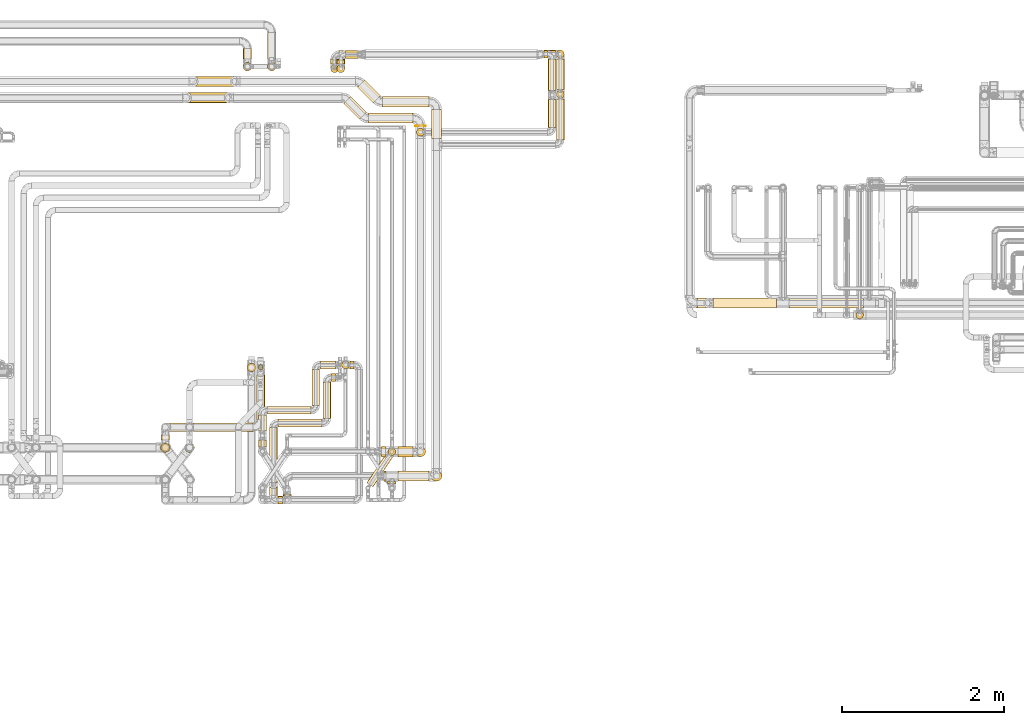
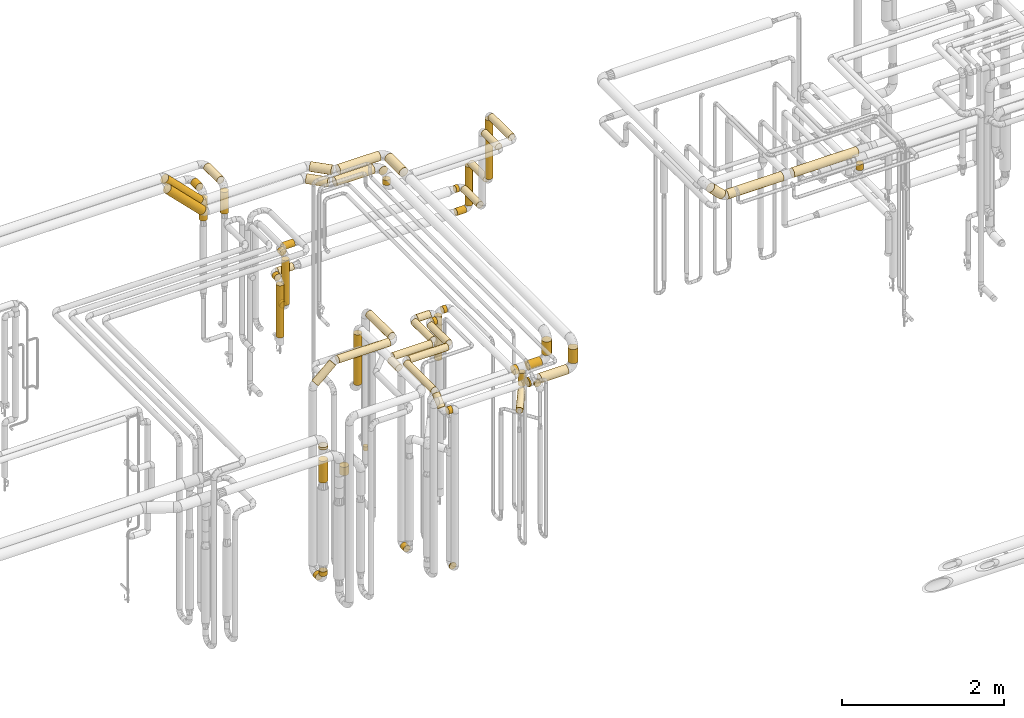
# One storey, part 16 of 827: 66 coverings.
"""IFC2X3 building model written with IfcOpenShell, lengths in millimetres."""

from ifc_helpers import new_model, entity, si_unit, converted_unit, derived_unit, direction, frame, origin, origin_2d_with_axis, place, context, subcontext, project, spatial, circle, extrude, element, save


model = new_model("IFC2X3")

# Units and contexts
model_context = context("Model", 3, precision=0.01, world=origin(), true_north=direction((6.12303176911189e-17, 1.0)))
body_context = subcontext(model_context, "Body", "Model", "MODEL_VIEW")
ifc_project = project(units=[si_unit("LENGTHUNIT", "METRE", prefix="MILLI"), si_unit("AREAUNIT", "SQUARE_METRE"), si_unit("VOLUMEUNIT", "CUBIC_METRE"), converted_unit("PLANEANGLEUNIT", "DEGREE", entity("IfcRatioMeasure", 0.0174532925199433), si_unit("PLANEANGLEUNIT", "RADIAN"), dimensions=[0, 0, 0, 0, 0, 0, 0]), si_unit("MASSUNIT", "GRAM", prefix="KILO"), derived_unit("MASSDENSITYUNIT", [(si_unit("MASSUNIT", "GRAM", prefix="KILO"), 1), (si_unit("LENGTHUNIT", "METRE"), -3)]), derived_unit("MOMENTOFINERTIAUNIT", [(si_unit("LENGTHUNIT", "METRE"), 4)]), si_unit("TIMEUNIT", "SECOND"), si_unit("FREQUENCYUNIT", "HERTZ"), si_unit("THERMODYNAMICTEMPERATUREUNIT", "DEGREE_CELSIUS"), derived_unit("THERMALTRANSMITTANCEUNIT", [(si_unit("MASSUNIT", "GRAM", prefix="KILO"), 1), (si_unit("THERMODYNAMICTEMPERATUREUNIT", "KELVIN"), -1), (si_unit("TIMEUNIT", "SECOND"), -3)]), derived_unit("VOLUMETRICFLOWRATEUNIT", [(si_unit("LENGTHUNIT", "METRE"), 3), (si_unit("TIMEUNIT", "SECOND"), -1)]), derived_unit("MASSFLOWRATEUNIT", [(si_unit("MASSUNIT", "GRAM", prefix="KILO"), 1), (si_unit("TIMEUNIT", "SECOND"), -1)]), derived_unit("ROTATIONALFREQUENCYUNIT", [(si_unit("TIMEUNIT", "SECOND"), -1)]), si_unit("ELECTRICCURRENTUNIT", "AMPERE"), si_unit("ELECTRICVOLTAGEUNIT", "VOLT"), si_unit("POWERUNIT", "WATT"), si_unit("FORCEUNIT", "NEWTON", prefix="KILO"), si_unit("ILLUMINANCEUNIT", "LUX"), si_unit("LUMINOUSFLUXUNIT", "LUMEN"), si_unit("LUMINOUSINTENSITYUNIT", "CANDELA"), derived_unit("USERDEFINED", [(si_unit("MASSUNIT", "GRAM", prefix="KILO"), -1), (si_unit("LENGTHUNIT", "METRE"), -2), (si_unit("TIMEUNIT", "SECOND"), 3), (si_unit("LUMINOUSFLUXUNIT", "LUMEN"), 1)]), derived_unit("LINEARVELOCITYUNIT", [(si_unit("LENGTHUNIT", "METRE"), 1), (si_unit("TIMEUNIT", "SECOND"), -1)]), si_unit("PRESSUREUNIT", "PASCAL"), derived_unit("USERDEFINED", [(si_unit("LENGTHUNIT", "METRE"), -2), (si_unit("MASSUNIT", "GRAM", prefix="KILO"), 1), (si_unit("TIMEUNIT", "SECOND"), -2)]), derived_unit("LINEARFORCEUNIT", [(si_unit("MASSUNIT", "GRAM", prefix="KILO"), 1), (si_unit("LENGTHUNIT", "METRE"), 1), (si_unit("TIMEUNIT", "SECOND"), -2), (si_unit("LENGTHUNIT", "METRE"), -1)]), derived_unit("PLANARFORCEUNIT", [(si_unit("MASSUNIT", "GRAM", prefix="KILO"), 1), (si_unit("LENGTHUNIT", "METRE"), 1), (si_unit("TIMEUNIT", "SECOND"), -2), (si_unit("LENGTHUNIT", "METRE"), -2)])], contexts=[model_context])

# Site, building, storey
site_placement = place(None, origin())
site = spatial("IfcSite", under=ifc_project, at=site_placement, CompositionType="ELEMENT")
building_placement = place(site_placement, origin())
building = spatial("IfcBuilding", under=site, at=building_placement, CompositionType="ELEMENT")
storey_placement = place(building_placement, frame((0.0, 0.0, 28200.0)))
storey = spatial("IfcBuildingStorey", under=building, at=storey_placement, Name="08", CompositionType="ELEMENT", Elevation=28200.0)

# Coverings
covering_1_placement = place(storey_placement, frame((48174.38, 18494.16, 2935.65)))
element("IfcCovering", 1, at=covering_1_placement, inside=storey, Name=":ADSK_", ObjectType=":ADSK_", PredefinedType="INSULATION", context=body_context, shape_type="SweptSolid", body=[
    extrude(circle(Radius=62.75, at=origin_2d_with_axis()), frame((0.0, 64.35, 64.35), z_axis=(1.0, 0.0, 0.0), x_axis=(0.0, -1.0, 0.0)), (0.0, 0.0, 1.0), 575.649711574558),
])
covering_2_placement = place(storey_placement, frame((47865.57, 18540.36, 2935.65)))
element("IfcCovering", 2, at=covering_2_placement, inside=storey, Name=":ADSK_", ObjectType=":ADSK_", PredefinedType="INSULATION", context=body_context, shape_type="SweptSolid", body=[
    extrude(circle(Radius=62.75, at=origin_2d_with_axis()), frame((45.97, 241.63, 64.35), z_axis=(0.707106781186485, -0.70710678118661, 0.0), x_axis=(-0.70710678118661, -0.707106781186485, 0.0)), (0.0, 0.0, 1.0), 276.715492530282),
])
covering_3_placement = place(storey_placement, frame((48780.69, 18106.53, 2935.65)))
element("IfcCovering", 3, at=covering_3_placement, inside=storey, Name=":ADSK_", ObjectType=":ADSK_", PredefinedType="INSULATION", context=body_context, shape_type="SweptSolid", body=[
    extrude(circle(Radius=62.75, at=origin_2d_with_axis()), frame((64.35, 0.0, 64.35), z_axis=(0.0, 1.0, 0.0), x_axis=(1.0, 0.0, 0.0)), (0.0, 0.0, 1.0), 356.978263748389),
])
covering_4_placement = place(storey_placement, frame((45805.68, 18744.58, 2981.86)))
element("IfcCovering", 4, at=covering_4_placement, inside=storey, Name=":ADSK_", ObjectType=":ADSK_", PredefinedType="INSULATION", context=body_context, shape_type="SweptSolid", body=[
    extrude(circle(Radius=62.75, at=origin_2d_with_axis()), frame((45.97, 64.35, 540.32), z_axis=(0.70710619769924, 0.00128465974007588, -0.70710619769924), x_axis=(0.000908391613723806, -0.999999174824336, -0.000908391613726204)), (0.0, 0.0, 1.0), 699.117459348992),
])
covering_5_placement = place(storey_placement, frame((48780.69, 13869.16, 2692.43)))
element("IfcCovering", 5, at=covering_5_placement, inside=storey, Name=":ADSK_", ObjectType=":ADSK_", PredefinedType="INSULATION", context=body_context, shape_type="SweptSolid", body=[
    extrude(circle(Radius=62.75, at=origin_2d_with_axis()), frame((64.35, 64.35, 0.0), z_axis=(0.0, 0.0, 1.0), x_axis=(0.0, 1.0, 0.0)), (0.0, 0.0, 1.0), 212.567197891267),
])
covering_6_placement = place(storey_placement, frame((48195.03, 13869.16, 2533.15)))
element("IfcCovering", 6, at=covering_6_placement, inside=storey, Name=":ADSK_", ObjectType=":ADSK_", PredefinedType="INSULATION", context=body_context, shape_type="SweptSolid", body=[
    extrude(circle(Radius=62.75, at=origin_2d_with_axis()), frame((0.0, 64.35, 64.35), z_axis=(1.0, 0.0, 0.0), x_axis=(0.0, -1.0, 0.0)), (0.0, 0.0, 1.0), 20.9896740925879),
])
covering_7_placement = place(storey_placement, frame((48241.43, 13843.1, 2546.9)))
element("IfcCovering", 7, at=covering_7_placement, inside=storey, Name=":ADSK_", ObjectType=":ADSK_", PredefinedType="INSULATION", context=body_context, shape_type="SweptSolid", body=[
    extrude(circle(Radius=49.0, at=origin_2d_with_axis()), frame((50.6, 0.0, 50.6), z_axis=(0.0, 1.0, 0.0), x_axis=(-1.0, 0.0, 0.0)), (0.0, 0.0, 1.0), 23.4071590179462),
])
covering_8_placement = place(storey_placement, frame((48368.02, 13869.16, 2533.15)))
element("IfcCovering", 8, at=covering_8_placement, inside=storey, Name=":ADSK_", ObjectType=":ADSK_", PredefinedType="INSULATION", context=body_context, shape_type="SweptSolid", body=[
    extrude(circle(Radius=62.75, at=origin_2d_with_axis()), frame((0.0, 64.35, 64.35), z_axis=(1.0, 0.0, 0.0), x_axis=(0.0, -1.0, 0.0)), (0.0, 0.0, 1.0), 382.010325907433),
])
covering_9_placement = place(storey_placement, frame((51989.91, 16008.03, 2681.53)))
element("IfcCovering", 9, at=covering_9_placement, inside=storey, Name=":ADSK_", ObjectType=":ADSK_", PredefinedType="INSULATION", context=body_context, shape_type="SweptSolid", body=[
    extrude(circle(Radius=62.75, at=origin_2d_with_axis()), frame((202.15, 64.35, 46.1), z_axis=(-0.709187265322835, 0.0, 0.705020157657863), x_axis=(0.0, 1.0, 0.0)), (0.0, 0.0, 1.0), 220.413379022299),
])
covering_10_placement = place(storey_placement, frame((52259.0, 16008.03, 2635.69)))
element("IfcCovering", 10, at=covering_10_placement, inside=storey, Name=":ADSK_", ObjectType=":ADSK_", PredefinedType="INSULATION", context=body_context, shape_type="SweptSolid", body=[
    extrude(circle(Radius=62.75, at=origin_2d_with_axis()), frame((0.0, 64.35, 64.35), z_axis=(1.0, 0.0, 0.0), x_axis=(0.0, 1.0, 0.0)), (0.0, 0.0, 1.0), 786.054556925048),
])
covering_11_placement = place(storey_placement, frame((53197.06, 16008.03, 2635.69)))
element("IfcCovering", 11, at=covering_11_placement, inside=storey, Name=":ADSK_", ObjectType=":ADSK_", PredefinedType="INSULATION", context=body_context, shape_type="SweptSolid", body=[
    extrude(circle(Radius=62.75, at=origin_2d_with_axis()), frame((0.0, 64.35, 64.35), z_axis=(1.0, 0.0, 0.0), x_axis=(0.0, 1.0, 0.0)), (0.0, 0.0, 1.0), 916.731510000015),
])
covering_12_placement = place(storey_placement, frame((48004.19, 18291.33, 2935.65)))
element("IfcCovering", 12, at=covering_12_placement, inside=storey, Name=":ADSK_", ObjectType=":ADSK_", PredefinedType="INSULATION", context=body_context, shape_type="SweptSolid", body=[
    extrude(circle(Radius=62.75, at=origin_2d_with_axis()), frame((0.0, 64.35, 64.35), z_axis=(1.0, 0.0, 0.0), x_axis=(0.0, -1.0, 0.0)), (0.0, 0.0, 1.0), 545.649711574547),
])
covering_13_placement = place(storey_placement, frame((47695.68, 18337.54, 2935.65)))
element("IfcCovering", 13, at=covering_13_placement, inside=storey, Name=":ADSK_", ObjectType=":ADSK_", PredefinedType="INSULATION", context=body_context, shape_type="SweptSolid", body=[
    extrude(circle(Radius=62.75, at=origin_2d_with_axis()), frame((45.97, 241.34, 64.35), z_axis=(0.707106781186555, -0.70710678118654, 0.0), x_axis=(-0.70710678118654, -0.707106781186555, 0.0)), (0.0, 0.0, 1.0), 276.299423149123),
])
covering_14_placement = place(storey_placement, frame((48580.5, 18256.53, 2935.65)))
element("IfcCovering", 14, at=covering_14_placement, inside=storey, Name=":ADSK_", ObjectType=":ADSK_", PredefinedType="INSULATION", context=body_context, shape_type="SweptSolid", body=[
    extrude(circle(Radius=62.75, at=origin_2d_with_axis()), frame((64.35, 0.0, 64.35), z_axis=(0.0, 1.0, 0.0), x_axis=(1.0, 0.0, 0.0)), (0.0, 0.0, 1.0), 4.1498271651662),
])
covering_15_placement = place(storey_placement, frame((45725.68, 18542.35, 2981.86)))
element("IfcCovering", 15, at=covering_15_placement, inside=storey, Name=":ADSK_", ObjectType=":ADSK_", PredefinedType="INSULATION", context=body_context, shape_type="SweptSolid", body=[
    extrude(circle(Radius=62.75, at=origin_2d_with_axis()), frame((45.97, 64.35, 540.32), z_axis=(0.707106781186548, 0.0, -0.707106781186548), x_axis=(0.0, -1.0, 0.0)), (0.0, 0.0, 1.0), 699.116571318315),
])
covering_16_placement = place(storey_placement, frame((48580.5, 14171.33, 2700.0)))
element("IfcCovering", 16, at=covering_16_placement, inside=storey, Name=":ADSK_", ObjectType=":ADSK_", PredefinedType="INSULATION", context=body_context, shape_type="SweptSolid", body=[
    extrude(circle(Radius=62.75, at=origin_2d_with_axis()), frame((64.35, 64.35, 0.0), z_axis=(0.0, 0.0, 1.0), x_axis=(-1.0, 0.0, 0.0)), (0.0, 0.0, 1.0), 205.000000000018),
])
covering_17_placement = place(storey_placement, frame((48164.84, 14171.33, 2540.65)))
element("IfcCovering", 17, at=covering_17_placement, inside=storey, Name=":ADSK_", ObjectType=":ADSK_", PredefinedType="INSULATION", context=body_context, shape_type="SweptSolid", body=[
    extrude(circle(Radius=62.75, at=origin_2d_with_axis()), frame((0.0, 64.35, 64.35), z_axis=(1.0, 0.0, 0.0), x_axis=(0.0, -1.0, 0.0)), (0.0, 0.0, 1.0), 51.1810195864036),
])
covering_18_placement = place(storey_placement, frame((48244.28, 14187.93, 2117.5)))
element("IfcCovering", 18, at=covering_18_placement, inside=storey, Name=":ADSK_", ObjectType=":ADSK_", PredefinedType="INSULATION", context=body_context, shape_type="SweptSolid", body=[
    extrude(circle(Radius=46.15, at=origin_2d_with_axis()), frame((47.75, 47.75, 0.0), z_axis=(0.0, 0.0, 1.0), x_axis=(0.0, 1.0, 0.0)), (0.0, 0.0, 1.0), 134.500000000013),
])
covering_19_placement = place(storey_placement, frame((48368.02, 14171.33, 2540.65)))
element("IfcCovering", 19, at=covering_19_placement, inside=storey, Name=":ADSK_", ObjectType=":ADSK_", PredefinedType="INSULATION", context=body_context, shape_type="SweptSolid", body=[
    extrude(circle(Radius=62.75, at=origin_2d_with_axis()), frame((0.0, 64.35, 64.35), z_axis=(1.0, 0.0, 0.0), x_axis=(0.0, -1.0, 0.0)), (0.0, 0.0, 1.0), 181.818980413621),
])
covering_20_placement = place(storey_placement, frame((47980.98, 13799.35, 2252.25)))
element("IfcCovering", 20, at=covering_20_placement, inside=storey, Name=":ADSK_", ObjectType=":ADSK_", PredefinedType="INSULATION", context=body_context, shape_type="SweptSolid", body=[
    extrude(circle(Radius=46.15, at=origin_2d_with_axis()), frame((40.1, 27.03, 47.75), z_axis=(0.551214458685239, 0.834363602116211, 0.0), x_axis=(-0.834363602116211, 0.551214458685239, 0.0)), (0.0, 0.0, 1.0), 442.846744306639),
])
covering_21_placement = place(storey_placement, frame((48244.28, 14187.93, 2348.0)))
element("IfcCovering", 21, at=covering_21_placement, inside=storey, Name=":ADSK_", ObjectType=":ADSK_", PredefinedType="INSULATION", context=body_context, shape_type="SweptSolid", body=[
    extrude(circle(Radius=46.15, at=origin_2d_with_axis()), frame((47.75, 47.75, 0.0), z_axis=(0.0, 0.0, 1.0), x_axis=(0.0, 1.0, 0.0)), (0.0, 0.0, 1.0), 192.999999999991),
])
covering_22_placement = place(storey_placement, frame((46453.47, 19086.22, 2945.65)))
element("IfcCovering", 22, at=covering_22_placement, inside=storey, Name=":ADSK_", ObjectType=":ADSK_", PredefinedType="INSULATION", context=body_context, shape_type="SweptSolid", body=[
    extrude(circle(Radius=52.75, at=origin_2d_with_axis()), frame((54.35, 0.0, 54.35), z_axis=(0.0, 1.0, 0.0), x_axis=(1.0, 0.0, 0.0)), (0.0, 0.0, 1.0), 126.011600000002),
])
covering_23_placement = place(storey_placement, frame((46453.47, 18936.88, 2580.0)))
element("IfcCovering", 23, at=covering_23_placement, inside=storey, Name=":ADSK_", ObjectType=":ADSK_", PredefinedType="INSULATION", context=body_context, shape_type="SweptSolid", body=[
    extrude(circle(Radius=52.75, at=origin_2d_with_axis()), frame((54.35, 54.35, 0.0), z_axis=(0.0, 0.0, 1.0), x_axis=(-1.0, 0.0, 0.0)), (0.0, 0.0, 1.0), 325.000000000008),
])
covering_24_placement = place(storey_placement, frame((54022.04, 15874.63, 2548.0)))
element("IfcCovering", 24, at=covering_24_placement, inside=storey, Name=":ADSK_", ObjectType=":ADSK_", PredefinedType="INSULATION", context=body_context, shape_type="SweptSolid", body=[
    extrude(circle(Radius=46.15, at=origin_2d_with_axis()), frame((47.75, 47.75, 0.0), z_axis=(0.0, 0.0, 1.0), x_axis=(-1.0, 0.0, 0.0)), (0.0, 0.0, 1.0), 87.999999999941),
])
covering_25_placement = place(storey_placement, frame((47301.4, 14804.03, 2949.4)))
element("IfcCovering", 25, at=covering_25_placement, inside=storey, Name=":ADSK_", ObjectType=":ADSK_", PredefinedType="INSULATION", context=body_context, shape_type="SweptSolid", body=[
    extrude(circle(Radius=49.0, at=origin_2d_with_axis()), frame((50.6, 0.0, 50.6), z_axis=(0.0, 1.0, 0.0), x_axis=(1.0, 0.0, 0.0)), (0.0, 0.0, 1.0), 446.000000000016),
])
covering_26_placement = place(storey_placement, frame((46642.19, 14296.53, 349.4)))
element("IfcCovering", 26, at=covering_26_placement, inside=storey, Name=":ADSK_", ObjectType=":ADSK_", PredefinedType="INSULATION", context=body_context, shape_type="SweptSolid", body=[
    extrude(circle(Radius=49.0, at=origin_2d_with_axis()), frame((50.6, 0.0, 50.6), z_axis=(0.0, 1.0, 0.0), x_axis=(1.0, 0.0, 0.0)), (0.0, 0.0, 1.0), 81.0000000000119),
])
covering_27_placement = place(storey_placement, frame((47409.0, 15256.43, 2949.4)))
element("IfcCovering", 27, at=covering_27_placement, inside=storey, Name=":ADSK_", ObjectType=":ADSK_", PredefinedType="INSULATION", context=body_context, shape_type="SweptSolid", body=[
    extrude(circle(Radius=49.0, at=origin_2d_with_axis()), frame((0.0, 50.6, 50.6), z_axis=(1.0, 0.0, 0.0), x_axis=(0.0, 1.0, 0.0)), (0.0, 0.0, 1.0), 186.00000000001),
])
covering_28_placement = place(storey_placement, frame((46749.79, 14696.43, 2949.4)))
element("IfcCovering", 28, at=covering_28_placement, inside=storey, Name=":ADSK_", ObjectType=":ADSK_", PredefinedType="INSULATION", context=body_context, shape_type="SweptSolid", body=[
    extrude(circle(Radius=49.0, at=origin_2d_with_axis()), frame((0.0, 50.6, 50.6), z_axis=(1.0, 0.0, 0.0), x_axis=(0.0, -1.0, 0.0)), (0.0, 0.0, 1.0), 545.208916433662),
])
covering_29_placement = place(storey_placement, frame((46642.19, 14491.53, 2949.4)))
element("IfcCovering", 29, at=covering_29_placement, inside=storey, Name=":ADSK_", ObjectType=":ADSK_", PredefinedType="INSULATION", context=body_context, shape_type="SweptSolid", body=[
    extrude(circle(Radius=49.0, at=origin_2d_with_axis()), frame((50.6, 0.0, 50.6), z_axis=(0.0, 1.0, 0.0), x_axis=(-1.0, 0.0, 0.0)), (0.0, 0.0, 1.0), 198.500000000011),
])
covering_30_placement = place(storey_placement, frame((47777.26, 15256.43, 2949.4)))
element("IfcCovering", 30, at=covering_30_placement, inside=storey, Name=":ADSK_", ObjectType=":ADSK_", PredefinedType="INSULATION", context=body_context, shape_type="SweptSolid", body=[
    extrude(circle(Radius=49.0, at=origin_2d_with_axis()), frame((0.0, 50.6, 50.6), z_axis=(1.0, 0.0, 0.0), x_axis=(0.0, -1.0, 0.0)), (0.0, 0.0, 1.0), 49.749999999993),
])
covering_31_placement = place(storey_placement, frame((47669.42, 15256.43, 2287.62)))
element("IfcCovering", 31, at=covering_31_placement, inside=storey, Name=":ADSK_", ObjectType=":ADSK_", PredefinedType="INSULATION", context=body_context, shape_type="SweptSolid", body=[
    extrude(circle(Radius=49.0, at=origin_2d_with_axis()), frame((50.6, 50.6, 0.0), z_axis=(0.0, 0.0, 1.0), x_axis=(-1.0, 0.0, 0.0)), (0.0, 0.0, 1.0), 655.375000000061),
])
covering_32_placement = place(storey_placement, frame((47437.4, 14645.75, 2949.4)))
element("IfcCovering", 32, at=covering_32_placement, inside=storey, Name=":ADSK_", ObjectType=":ADSK_", PredefinedType="INSULATION", context=body_context, shape_type="SweptSolid", body=[
    extrude(circle(Radius=49.0, at=origin_2d_with_axis()), frame((50.6, 0.0, 50.6), z_axis=(0.0, 1.0, 0.0), x_axis=(1.0, 0.0, 0.0)), (0.0, 0.0, 1.0), 448.489185095073),
])
covering_33_placement = place(storey_placement, frame((46947.93, 13694.22, 349.4)))
element("IfcCovering", 33, at=covering_33_placement, inside=storey, Name=":ADSK_", ObjectType=":ADSK_", PredefinedType="INSULATION", context=body_context, shape_type="SweptSolid", body=[
    extrude(circle(Radius=49.0, at=origin_2d_with_axis()), frame((50.6, 0.0, 50.6), z_axis=(0.0, 1.0, 0.0), x_axis=(-1.0, 0.0, 0.0)), (0.0, 0.0, 1.0), 12.5440336639325),
])
covering_34_placement = place(storey_placement, frame((47545.0, 15100.64, 2949.4)))
element("IfcCovering", 34, at=covering_34_placement, inside=storey, Name=":ADSK_", ObjectType=":ADSK_", PredefinedType="INSULATION", context=body_context, shape_type="SweptSolid", body=[
    extrude(circle(Radius=49.0, at=origin_2d_with_axis()), frame((0.0, 50.6, 50.6), z_axis=(1.0, 0.0, 0.0), x_axis=(0.0, 1.0, 0.0)), (0.0, 0.0, 1.0), 49.749999999993),
])
covering_35_placement = place(storey_placement, frame((46885.0, 13586.24, 2759.19)))
element("IfcCovering", 35, at=covering_35_placement, inside=storey, Name=":ADSK_", ObjectType=":ADSK_", PredefinedType="INSULATION", context=body_context, shape_type="SweptSolid", body=[
    extrude(circle(Radius=49.0, at=origin_2d_with_axis()), frame((0.0, 50.6, 50.6), z_axis=(1.0, -2.35333717118907e-08, 0.0), x_axis=(-2.35333717118907e-08, -1.0, 0.0)), (0.0, 0.0, 1.0), 56.5308175749362),
])
covering_36_placement = place(storey_placement, frame((46885.0, 14538.15, 2949.4)))
element("IfcCovering", 36, at=covering_36_placement, inside=storey, Name=":ADSK_", ObjectType=":ADSK_", PredefinedType="INSULATION", context=body_context, shape_type="SweptSolid", body=[
    extrude(circle(Radius=49.0, at=origin_2d_with_axis()), frame((0.0, 50.6, 50.6), z_axis=(1.0, 0.0, 0.0), x_axis=(0.0, -1.0, 0.0)), (0.0, 0.0, 1.0), 546.000000000006),
])
covering_37_placement = place(storey_placement, frame((46777.4, 13856.65, 2949.4)))
element("IfcCovering", 37, at=covering_37_placement, inside=storey, Name=":ADSK_", ObjectType=":ADSK_", PredefinedType="INSULATION", context=body_context, shape_type="SweptSolid", body=[
    extrude(circle(Radius=49.0, at=origin_2d_with_axis()), frame((50.6, 0.0, 50.6), z_axis=(0.0, 1.0, 0.0), x_axis=(1.0, 0.0, 0.0)), (0.0, 0.0, 1.0), 675.09993070178),
])
covering_38_placement = place(storey_placement, frame((46777.4, 13642.17, 2812.58)))
element("IfcCovering", 38, at=covering_38_placement, inside=storey, Name=":ADSK_", ObjectType=":ADSK_", PredefinedType="INSULATION", context=body_context, shape_type="SweptSolid", body=[
    extrude(circle(Radius=49.0, at=origin_2d_with_axis()), frame((50.6, 35.65, 36.82), z_axis=(0.0, 0.718969901615608, 0.695041207822128), x_axis=(-1.0, 0.0, 0.0)), (0.0, 0.0, 1.0), 193.624123419369),
])
covering_39_placement = place(storey_placement, frame((50221.44, 18237.53, 2749.4)))
element("IfcCovering", 39, at=covering_39_placement, inside=storey, Name=":ADSK_", ObjectType=":ADSK_", PredefinedType="INSULATION", context=body_context, shape_type="SweptSolid", body=[
    extrude(circle(Radius=49.0, at=origin_2d_with_axis()), frame((50.6, 0.0, 50.6), z_axis=(0.0, 1.0, 0.0), x_axis=(-1.0, 0.0, 0.0)), (0.0, 0.0, 1.0), 345.999999999954),
])
covering_40_placement = place(storey_placement, frame((48594.25, 18129.93, 2857.0)))
element("IfcCovering", 40, at=covering_40_placement, inside=storey, Name=":ADSK_", ObjectType=":ADSK_", PredefinedType="INSULATION", context=body_context, shape_type="SweptSolid", body=[
    extrude(circle(Radius=49.0, at=origin_2d_with_axis()), frame((50.6, 50.6, 0.0)), (0.0, 0.0, 1.0), 75.9999999999611),
])
covering_41_placement = place(storey_placement, frame((50221.44, 18697.53, 1599.4)))
element("IfcCovering", 41, at=covering_41_placement, inside=storey, Name=":ADSK_", ObjectType=":ADSK_", PredefinedType="INSULATION", context=body_context, shape_type="SweptSolid", body=[
    extrude(circle(Radius=49.0, at=origin_2d_with_axis()), frame((50.6, 0.0, 50.6), z_axis=(0.0, 1.0, 0.0), x_axis=(-1.0, 0.0, 0.0)), (0.0, 0.0, 1.0), 390.99999997821),
])
covering_42_placement = place(storey_placement, frame((50172.3, 19094.93, 1599.4)))
element("IfcCovering", 42, at=covering_42_placement, inside=storey, Name=":ADSK_", ObjectType=":ADSK_", PredefinedType="INSULATION", context=body_context, shape_type="SweptSolid", body=[
    extrude(circle(Radius=49.0, at=origin_2d_with_axis()), frame((0.0, 50.6, 50.6), z_axis=(1.0, 0.0, 0.0), x_axis=(0.0, -1.0, 0.0)), (0.0, 0.0, 1.0), 42.7379771478646),
])
covering_43_placement = place(storey_placement, frame((47718.17, 19090.63, 1599.4)))
element("IfcCovering", 43, at=covering_43_placement, inside=storey, Name=":ADSK_", ObjectType=":ADSK_", PredefinedType="INSULATION", context=body_context, shape_type="SweptSolid", body=[
    extrude(circle(Radius=49.0, at=origin_2d_with_axis()), frame((0.0, 50.6, 50.6), z_axis=(1.0, 0.0, 0.0), x_axis=(0.0, -1.0, 0.0)), (0.0, 0.0, 1.0), 156.125000000036),
])
covering_44_placement = place(storey_placement, frame((47610.58, 19023.22, 1599.4)))
element("IfcCovering", 44, at=covering_44_placement, inside=storey, Name=":ADSK_", ObjectType=":ADSK_", PredefinedType="INSULATION", context=body_context, shape_type="SweptSolid", body=[
    extrude(circle(Radius=49.0, at=origin_2d_with_axis()), frame((50.6, 0.0, 50.6), z_axis=(0.0, 1.0, 0.0), x_axis=(1.0, 0.0, 0.0)), (0.0, 0.0, 1.0), 61.0000000000208),
])
covering_45_placement = place(storey_placement, frame((47610.58, 18915.63, 918.88)))
element("IfcCovering", 45, at=covering_45_placement, inside=storey, Name=":ADSK_", ObjectType=":ADSK_", PredefinedType="INSULATION", context=body_context, shape_type="SweptSolid", body=[
    extrude(circle(Radius=49.0, at=origin_2d_with_axis()), frame((50.6, 50.6, 0.0), z_axis=(0.0, 0.0, 1.0), x_axis=(-1.0, 0.0, 0.0)), (0.0, 0.0, 1.0), 674.12499999997),
])
covering_46_placement = place(storey_placement, frame((47610.58, 19023.22, 811.28)))
element("IfcCovering", 46, at=covering_46_placement, inside=storey, Name=":ADSK_", ObjectType=":ADSK_", PredefinedType="INSULATION", context=body_context, shape_type="SweptSolid", body=[
    extrude(circle(Radius=49.0, at=origin_2d_with_axis()), frame((50.6, 0.0, 50.6), z_axis=(0.0, 1.0, 0.0), x_axis=(-1.0, 0.0, 0.0)), (0.0, 0.0, 1.0), 48.0000000000086),
])
covering_47_placement = place(storey_placement, frame((50321.44, 18087.53, 2949.4)))
element("IfcCovering", 47, at=covering_47_placement, inside=storey, Name=":ADSK_", ObjectType=":ADSK_", PredefinedType="INSULATION", context=body_context, shape_type="SweptSolid", body=[
    extrude(circle(Radius=49.0, at=origin_2d_with_axis()), frame((50.6, 0.0, 50.6), z_axis=(0.0, 1.0, 0.0), x_axis=(-1.0, 0.0, 0.0)), (0.0, 0.0, 1.0), 506.000000000015),
])
covering_48_placement = place(storey_placement, frame((50321.44, 18599.93, 2057.0)))
element("IfcCovering", 48, at=covering_48_placement, inside=storey, Name=":ADSK_", ObjectType=":ADSK_", PredefinedType="INSULATION", context=body_context, shape_type="SweptSolid", body=[
    extrude(circle(Radius=49.0, at=origin_2d_with_axis()), frame((50.6, 50.6, 0.0), z_axis=(0.0, 0.0, 1.0), x_axis=(-1.0, 0.0, 0.0)), (0.0, 0.0, 1.0), 886.000000000011),
])
covering_49_placement = place(storey_placement, frame((50321.44, 18707.53, 1949.4)))
element("IfcCovering", 49, at=covering_49_placement, inside=storey, Name=":ADSK_", ObjectType=":ADSK_", PredefinedType="INSULATION", context=body_context, shape_type="SweptSolid", body=[
    extrude(circle(Radius=49.0, at=origin_2d_with_axis()), frame((50.6, 0.0, 50.6), z_axis=(0.0, 1.0, 0.0), x_axis=(-1.0, 0.0, 0.0)), (0.0, 0.0, 1.0), 381.000000000007),
])
covering_50_placement = place(storey_placement, frame((50321.44, 19094.93, 1357.0)))
element("IfcCovering", 50, at=covering_50_placement, inside=storey, Name=":ADSK_", ObjectType=":ADSK_", PredefinedType="INSULATION", context=body_context, shape_type="SweptSolid", body=[
    extrude(circle(Radius=49.0, at=origin_2d_with_axis()), frame((50.6, 50.6, 0.0), z_axis=(0.0, 0.0, 1.0), x_axis=(-1.0, 0.0, 0.0)), (0.0, 0.0, 1.0), 586.00000000001),
])
covering_51_placement = place(storey_placement, frame((50185.03, 19094.93, 1249.4)))
element("IfcCovering", 51, at=covering_51_placement, inside=storey, Name=":ADSK_", ObjectType=":ADSK_", PredefinedType="INSULATION", context=body_context, shape_type="SweptSolid", body=[
    extrude(circle(Radius=49.0, at=origin_2d_with_axis()), frame((0.0, 50.6, 50.6), z_axis=(1.0, 0.0, 0.0), x_axis=(0.0, -1.0, 0.0)), (0.0, 0.0, 1.0), 130.000000000005),
])
covering_52_placement = place(storey_placement, frame((47641.3, 19090.63, 1249.4)))
element("IfcCovering", 52, at=covering_52_placement, inside=storey, Name=":ADSK_", ObjectType=":ADSK_", PredefinedType="INSULATION", context=body_context, shape_type="SweptSolid", body=[
    extrude(circle(Radius=49.0, at=origin_2d_with_axis()), frame((0.0, 50.6, 50.6), z_axis=(1.0, 0.0, 0.0), x_axis=(0.0, -1.0, 0.0)), (0.0, 0.0, 1.0), 220.000000000002),
])
covering_53_placement = place(storey_placement, frame((47533.7, 19023.22, 1249.4)))
element("IfcCovering", 53, at=covering_53_placement, inside=storey, Name=":ADSK_", ObjectType=":ADSK_", PredefinedType="INSULATION", context=body_context, shape_type="SweptSolid", body=[
    extrude(circle(Radius=49.0, at=origin_2d_with_axis()), frame((50.6, 0.0, 50.6), z_axis=(0.0, 1.0, 0.0), x_axis=(1.0, 0.0, 0.0)), (0.0, 0.0, 1.0), 61.0000000000143),
])
covering_54_placement = place(storey_placement, frame((47533.7, 18915.63, 457.0)))
element("IfcCovering", 54, at=covering_54_placement, inside=storey, Name=":ADSK_", ObjectType=":ADSK_", PredefinedType="INSULATION", context=body_context, shape_type="SweptSolid", body=[
    extrude(circle(Radius=49.0, at=origin_2d_with_axis()), frame((50.6, 50.6, 0.0)), (0.0, 0.0, 1.0), 785.999999709128),
])
covering_55_placement = place(storey_placement, frame((45439.88, 14381.62, 295.65)))
element("IfcCovering", 55, at=covering_55_placement, inside=storey, Name=":ADSK_", ObjectType=":ADSK_", PredefinedType="INSULATION", context=body_context, shape_type="SweptSolid", body=[
    extrude(circle(Radius=52.75, at=origin_2d_with_axis()), frame((54.35, 0.0, 54.35), z_axis=(0.0, 1.0, 0.0), x_axis=(1.0, 0.0, 0.0)), (0.0, 0.0, 1.0), 61.4604775254828),
])
covering_56_placement = place(storey_placement, frame((45439.88, 14232.27, 445.0)))
element("IfcCovering", 56, at=covering_56_placement, inside=storey, Name=":ADSK_", ObjectType=":ADSK_", PredefinedType="INSULATION", context=body_context, shape_type="SweptSolid", body=[
    extrude(circle(Radius=52.75, at=origin_2d_with_axis()), frame((54.35, 54.35, 0.0)), (0.0, 0.0, 1.0), 65.0000000000242),
])
covering_57_placement = place(storey_placement, frame((45841.83, 14483.73, 3345.65)))
element("IfcCovering", 57, at=covering_57_placement, inside=storey, Name=":ADSK_", ObjectType=":ADSK_", PredefinedType="INSULATION", context=body_context, shape_type="SweptSolid", body=[
    extrude(circle(Radius=52.75, at=origin_2d_with_axis()), frame((0.0, 54.35, 54.35), z_axis=(1.0, 0.0, 0.0), x_axis=(0.0, -1.0, 0.0)), (0.0, 0.0, 1.0), 733.72992241483),
])
covering_58_placement = place(storey_placement, frame((46616.22, 14633.08, 3345.65)))
element("IfcCovering", 58, at=covering_58_placement, inside=storey, Name=":ADSK_", ObjectType=":ADSK_", PredefinedType="INSULATION", context=body_context, shape_type="SweptSolid", body=[
    extrude(circle(Radius=52.75, at=origin_2d_with_axis()), frame((54.35, 0.0, 54.35), z_axis=(0.0, 1.0, 0.0), x_axis=(-1.0, 0.0, 0.0)), (0.0, 0.0, 1.0), 550.000000000011),
])
covering_59_placement = place(storey_placement, frame((45489.92, 14483.73, 3112.41)))
element("IfcCovering", 59, at=covering_59_placement, inside=storey, Name=":ADSK_", ObjectType=":ADSK_", PredefinedType="INSULATION", context=body_context, shape_type="SweptSolid", body=[
    extrude(circle(Radius=52.75, at=origin_2d_with_axis()), frame((36.48, 54.35, 41.17), z_axis=(0.750137300458903, 0.0, 0.661282111099514), x_axis=(0.0, 1.0, 0.0)), (0.0, 0.0, 1.0), 336.753261279577),
])
covering_60_placement = place(storey_placement, frame((45433.82, 14226.22, 1854.0)))
element("IfcCovering", 60, at=covering_60_placement, inside=storey, Name=":ADSK_", ObjectType=":ADSK_", PredefinedType="INSULATION", context=body_context, shape_type="SweptSolid", body=[
    extrude(circle(Radius=59.25, at=origin_2d_with_axis()), frame((60.4, 60.4, 0.0), z_axis=(0.0, 0.0, 1.0), x_axis=(-0.798635510047303, -0.601815023152035, 0.0)), (0.0, 0.0, 1.0), 325.000000000008),
])
covering_61_placement = place(storey_placement, frame((46636.47, 15243.98, 1305.25)))
element("IfcCovering", 61, at=covering_61_placement, inside=storey, Name=":ADSK_", ObjectType=":ADSK_", PredefinedType="INSULATION", context=body_context, shape_type="SweptSolid", body=[
    extrude(circle(Radius=32.5, at=origin_2d_with_axis()), frame((34.1, 34.1, 0.0), z_axis=(0.0, 0.0, 1.0), x_axis=(0.0, -1.0, 0.0)), (0.0, 0.0, 1.0), 61.0000000000035),
])
covering_62_placement = place(storey_placement, frame((46502.43, 15221.02, 2345.05)))
element("IfcCovering", 62, at=covering_62_placement, inside=storey, Name=":ADSK_", ObjectType=":ADSK_", PredefinedType="INSULATION", context=body_context, shape_type="SweptSolid", body=[
    extrude(circle(Radius=52.75, at=origin_2d_with_axis()), frame((54.35, 54.35, 0.0)), (0.0, 0.0, 1.0), 760.000000000018),
])
covering_63_placement = place(storey_placement, frame((45732.67, 14226.22, 1860.0)))
element("IfcCovering", 63, at=covering_63_placement, inside=storey, Name=":ADSK_", ObjectType=":ADSK_", PredefinedType="INSULATION", context=body_context, shape_type="SweptSolid", body=[
    extrude(circle(Radius=59.25, at=origin_2d_with_axis()), frame((60.4, 60.4, 0.0), z_axis=(0.0, 0.0, 1.0), x_axis=(0.798635510047289, -0.601815023152053, 0.0)), (0.0, 0.0, 1.0), 126.000000000019),
])
covering_64_placement = place(storey_placement, frame((46753.22, 19086.22, 2945.4)))
element("IfcCovering", 64, at=covering_64_placement, inside=storey, Name=":ADSK_", ObjectType=":ADSK_", PredefinedType="INSULATION", context=body_context, shape_type="SweptSolid", body=[
    extrude(circle(Radius=53.0, at=origin_2d_with_axis()), frame((54.6, 0.0, 54.6), z_axis=(0.0, 1.0, 0.0), x_axis=(1.0, 0.0, 0.0)), (0.0, 0.0, 1.0), 326.0116),
])
covering_65_placement = place(storey_placement, frame((46753.22, 18936.63, 2580.0)))
element("IfcCovering", 65, at=covering_65_placement, inside=storey, Name=":ADSK_", ObjectType=":ADSK_", PredefinedType="INSULATION", context=body_context, shape_type="SweptSolid", body=[
    extrude(circle(Radius=53.0, at=origin_2d_with_axis()), frame((54.6, 54.6, 0.0)), (0.0, 0.0, 1.0), 325.000000000017),
])
covering_66_placement = place(storey_placement, frame((45433.38, 14225.77, 2351.0)))
element("IfcCovering", 66, at=covering_66_placement, inside=storey, Name=":ADSK_", ObjectType=":ADSK_", PredefinedType="INSULATION", context=body_context, shape_type="SweptSolid", body=[
    extrude(circle(Radius=59.25, at=origin_2d_with_axis()), frame((60.85, 60.85, 0.0), z_axis=(0.0, 0.0, 1.0), x_axis=(0.0, 1.0, 0.0)), (0.0, 0.0, 1.0), 34.9999999999747),
])

save(model, "model.ifc")
